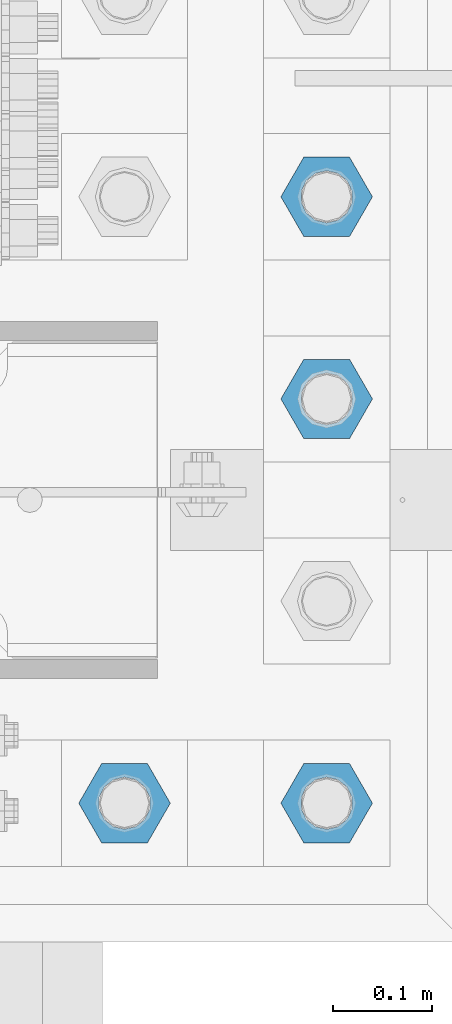
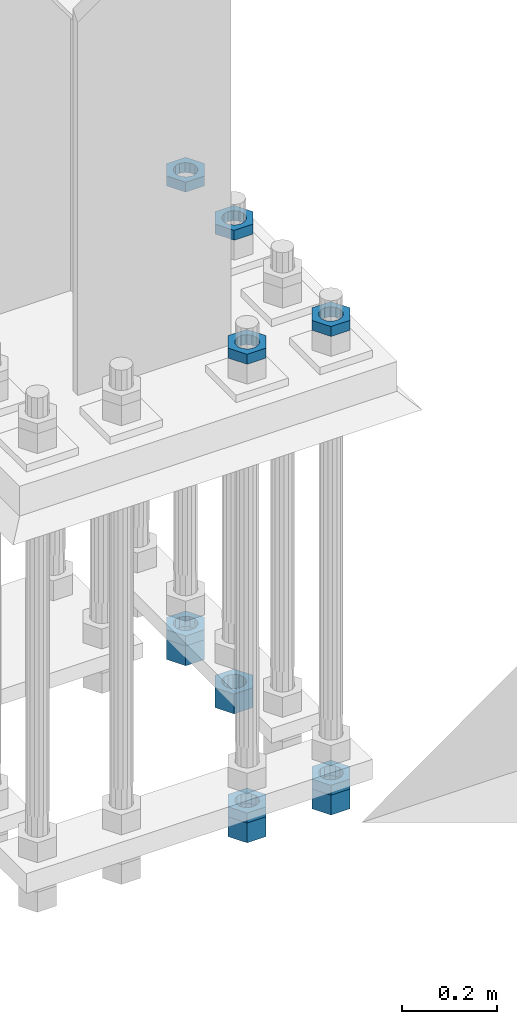
# One storey, part 2093 of 3843: 11 beams, 1 element without a shape of its own.
"""IFC2X3 building model written with IfcOpenShell, lengths in millimetres."""

import ifcopenshell
import ifcopenshell.guid

model = None  # the IFC model being written
_history = None  # IfcOwnerHistory: only IFC2X3 demands one
_inside = {}  # id of a spatial element -> (the spatial element, [elements in it])
_under = {}  # id of a project, library or spatial element -> (it, [spatial elements below it])
_declared = {}  # id of a project -> (the project, [libraries it declares])
_typed = {}  # id of a type object -> (the type object, [elements of that type])
_made_of = {}  # id of a material, layer set ... -> (it, [elements and type objects made of it])


def new_model(schema):
    """Start an empty IFC model of exactly this schema.

    Asked for "IFC4X3", IfcOpenShell would pick the latest addendum, in which some entities
    have other attributes; the version numbers below select the first issue.
    IFC2X3 requires an IfcOwnerHistory on every rooted entity: one is made here for all.
    """
    global model, _history
    if schema == "IFC4X3":
        model = ifcopenshell.file(schema_version=(4, 3, 0, 0))
    else:
        model = ifcopenshell.file(schema=schema)
    _inside.clear()
    _under.clear()
    _declared.clear()
    _typed.clear()
    _made_of.clear()
    _history = None
    if model.schema == "IFC2X3":
        org = make("IfcOrganization", Name="unknown")
        user = make(
            "IfcPersonAndOrganization",
            ThePerson=make("IfcPerson", FamilyName="unknown"),
            TheOrganization=org,
        )
        app = make(
            "IfcApplication",
            ApplicationDeveloper=org,
            Version="unknown",
            ApplicationFullName="unknown",
            ApplicationIdentifier="unknown",
        )
        _history = make(
            "IfcOwnerHistory",
            OwningUser=user,
            OwningApplication=app,
            ChangeAction="ADDED",
            CreationDate=0,
        )
    return model


def make(cls, **values):
    """One entity of the class cls with the attributes given. An attribute that is None is left unset."""
    return model.create_entity(
        cls, **{name: value for name, value in values.items() if value is not None}
    )


def rooted(cls, **values):
    """An entity with a GlobalId (a new one), such as an element, a storey or a relation."""
    return make(cls, GlobalId=ifcopenshell.guid.new(), OwnerHistory=_history, **values)


def si_unit(unit_type, name, prefix=None):
    """IfcSIUnit, for example si_unit("LENGTHUNIT", "METRE", prefix="MILLI")."""
    return make("IfcSIUnit", UnitType=unit_type, Prefix=prefix, Name=name)


def assignment(units):
    """IfcUnitAssignment: the units of a project."""
    return None if units is None else make("IfcUnitAssignment", Units=units)


def point(xyz):
    """IfcCartesianPoint."""
    return None if xyz is None else make("IfcCartesianPoint", Coordinates=xyz)


def direction(xyz):
    """IfcDirection."""
    return None if xyz is None else make("IfcDirection", DirectionRatios=xyz)


def frame(location, z_axis=None, x_axis=None):
    """IfcAxis2Placement3D, a coordinate frame: its origin and axes. An axis left out is left unset."""
    return make(
        "IfcAxis2Placement3D",
        Location=point(location),
        Axis=direction(z_axis),
        RefDirection=direction(x_axis),
    )


def origin_with_axes():
    """The frame at (0, 0, 0) with the z axis (0, 0, 1) and the x axis (1, 0, 0) written out."""
    return frame((0.0, 0.0, 0.0), z_axis=(0.0, 0.0, 1.0), x_axis=(1.0, 0.0, 0.0))


def place(relative_to, where):
    """IfcLocalPlacement: puts the frame where relative to a parent placement (None: the world)."""
    return make(
        "IfcLocalPlacement", PlacementRelTo=relative_to, RelativePlacement=where
    )


def context(
    kind, dimensions, precision=None, world=None, true_north=None, identifier=None
):
    """IfcGeometricRepresentationContext, for example the 3D "Model" context."""
    return make(
        "IfcGeometricRepresentationContext",
        ContextIdentifier=identifier,
        ContextType=kind,
        CoordinateSpaceDimension=dimensions,
        Precision=precision,
        WorldCoordinateSystem=world,
        TrueNorth=true_north,
    )


def subcontext(parent, identifier, kind, view, scale=None):
    """IfcGeometricRepresentationSubContext, for example "Body" below "Model"."""
    return make(
        "IfcGeometricRepresentationSubContext",
        ContextIdentifier=identifier,
        ContextType=kind,
        ParentContext=parent,
        TargetScale=scale,
        TargetView=view,
    )


def project(units=None, contexts=None):
    """IfcProject with its units and contexts."""
    return rooted(
        "IfcProject",
        Name="project",
        RepresentationContexts=contexts,
        UnitsInContext=assignment(units),
    )


def spatial(cls, under=None, at=None, **own):
    """A site, building, storey or space (cls), placed at a placement, below another one or the project."""
    s = rooted(cls, ObjectPlacement=at, **own)
    if under is not None:
        _under.setdefault(under.id(), (under, []))[1].append(s)
    return s


def faces_of(points, faces, orient=None, outer=None):
    """IfcFace entities. A face is a list of loops; a loop is a list of indices into points, from 0.

    orient and outer hold one flag for each loop. By default every Orientation is true, the
    first loop of a face is its IfcFaceOuterBound and the others are IfcFaceBound.
    """
    made = []
    for i, loops in enumerate(faces):
        bounds = []
        for j, loop in enumerate(loops):
            is_outer = j == 0 if outer is None else outer[i][j]
            bounds.append(
                make(
                    "IfcFaceOuterBound" if is_outer else "IfcFaceBound",
                    Bound=make("IfcPolyLoop", Polygon=[points[k] for k in loop]),
                    Orientation=True if orient is None else orient[i][j],
                )
            )
        made.append(make("IfcFace", Bounds=bounds))
    return made


def faceted_brep(points, faces, orient=None, outer=None, voids=None):
    """IfcFacetedBrep: a solid bounded by flat faces; with voids (closed shells), ...WithVoids."""
    shared = [point(p) for p in points]
    hull = make("IfcClosedShell", CfsFaces=faces_of(shared, faces, orient, outer))
    if voids is None:
        return make("IfcFacetedBrep", Outer=hull)
    return make(
        "IfcFacetedBrepWithVoids",
        Outer=hull,
        Voids=[
            make(cls, CfsFaces=faces_of(shared, fs, o, b)) for cls, fs, o, b in voids
        ],
    )


def shape(context_of_items, identifier, shape_type, items):
    """IfcShapeRepresentation: the items that make up one representation, for example the "Body"."""
    return make(
        "IfcShapeRepresentation",
        ContextOfItems=context_of_items,
        RepresentationIdentifier=identifier,
        RepresentationType=shape_type,
        Items=items,
    )


def material(Name=None, Category=None):
    """IfcMaterial."""
    return make("IfcMaterial", Name=Name, Category=Category)


def made_of(thing, what):
    """Note that an element or type object is made of a material, layer set ...; save() writes the relation."""
    if what is not None:
        _made_of.setdefault(what.id(), (what, []))[1].append(thing)
    return thing


def type_object(cls, material=None, **own):
    """A type object (cls), such as IfcWallType, which elements share."""
    return made_of(rooted(cls, **own), material)


def element(
    cls,
    number,
    at=None,
    inside=None,
    cuts=None,
    type_object=None,
    material=None,
    context=None,
    identifier="Body",
    shape_type=None,
    held_by="IfcProductDefinitionShape",
    body=None,
    shapes=None,
    **own,
):
    """One element of the class cls, such as IfcWall. Its Tag is "e" and its number.

    at: its placement. inside: the storey or other place that contains it. cuts: it is an
    opening in that element (IfcRelVoidsElement). A single representation is given by context,
    identifier, shape_type and body (its items); several are given by shapes. held_by: the class
    of the entity that holds the representations. save() writes the other relations.
    """
    e = rooted(cls, Tag="e%d" % number, ObjectPlacement=at, **own)
    if body is not None:
        shapes = [shape(context, identifier, shape_type, body)]
    if shapes is not None:
        e.Representation = make(held_by, Representations=shapes)
    if inside is not None:
        _inside.setdefault(inside.id(), (inside, []))[1].append(e)
    if cuts is not None:
        rooted(
            "IfcRelVoidsElement", RelatingBuildingElement=cuts, RelatedOpeningElement=e
        )
    if type_object is not None:
        _typed.setdefault(type_object.id(), (type_object, []))[1].append(e)
    return made_of(e, material)


def aggregate(whole, parts):
    """IfcRelAggregates: a whole, such as a stair, and the parts it consists of."""
    return rooted("IfcRelAggregates", RelatingObject=whole, RelatedObjects=parts)


def save(model, path):
    """Write the relations noted so far, then the file.

    IfcRelAggregates (storeys below a building ...), IfcRelContainedInSpatialStructure (elements
    in a storey), IfcRelDefinesByType, IfcRelAssociatesMaterial and IfcRelDeclares: one each for
    every whole, place, type object, material and project.
    """
    for whole, parts in _under.values():
        aggregate(whole, parts)
    for where, things in _inside.values():
        rooted(
            "IfcRelContainedInSpatialStructure",
            RelatedElements=things,
            RelatingStructure=where,
        )
    for kind, things in _typed.values():
        rooted("IfcRelDefinesByType", RelatedObjects=things, RelatingType=kind)
    for what, things in _made_of.values():
        rooted("IfcRelAssociatesMaterial", RelatedObjects=things, RelatingMaterial=what)
    for by, libraries in _declared.values():
        rooted("IfcRelDeclares", RelatingContext=by, RelatedDefinitions=libraries)
    model.write(path)


model = new_model("IFC2X3")

# Units and contexts
model_context = context("Model", 3, precision=1e-05, world=origin_with_axes())
body_context = subcontext(model_context, "Body", "Model", "MODEL_VIEW")
ifc_project = project(units=[si_unit("LENGTHUNIT", "METRE", prefix="MILLI"), si_unit("AREAUNIT", "SQUARE_METRE"), si_unit("VOLUMEUNIT", "CUBIC_METRE"), si_unit("MASSUNIT", "GRAM", prefix="KILO"), si_unit("TIMEUNIT", "SECOND"), si_unit("PLANEANGLEUNIT", "RADIAN"), si_unit("SOLIDANGLEUNIT", "STERADIAN"), si_unit("THERMODYNAMICTEMPERATUREUNIT", "DEGREE_CELSIUS"), si_unit("LUMINOUSINTENSITYUNIT", "LUMEN")], contexts=[model_context])

# Site, building, storey
site_placement = place(None, origin_with_axes())
site = spatial("IfcSite", under=ifc_project, at=site_placement, CompositionType="ELEMENT")
building_placement = place(site_placement, origin_with_axes())
building = spatial("IfcBuilding", under=site, at=building_placement, Name="Undefined", CompositionType="ELEMENT")
storey_placement = place(building_placement, origin_with_axes())
storey = spatial("IfcBuildingStorey", under=building, at=storey_placement, Name="Undefined", CompositionType="ELEMENT", Elevation=0.0)

# Assembly, beams
assembly_placement = place(storey_placement, origin_with_axes())
assembly = element("IfcElementAssembly", 1, at=assembly_placement, inside=storey, Name="TEMPLATE", AssemblyPlace="NOTDEFINED", PredefinedType="RIGID_FRAME")
ifc_material = material(Name="STEEL/A572-50")
beam_type_1 = type_object("IfcBeamType", Name="2_HALF_NUT", PredefinedType="NOTDEFINED")
beam_1_placement = place(assembly_placement, frame((56083.2, 20002.5, 29775.15), z_axis=(0.0, 1.0, 0.0), x_axis=(0.0, 0.0, -1.0)))
beam_1 = element("IfcBeam", 2, at=beam_1_placement, type_object=beam_type_1, material=ifc_material, Name="NUT", ObjectType="2_HALF_NUT", context=body_context, shape_type="Brep", body=[
    faceted_brep([(0.0, -46.0369987487793, 0.0), (0.0, -23.0184993743896, -39.869213104248), (25.4000000000015, -23.0184993743896, -39.869213104248), (25.4000000000015, -46.0369987487793, 0.0), (0.0, 23.0184993743896, -39.869213104248), (25.4000000000015, 23.0184993743896, -39.869213104248), (0.0, 46.0369987487793, 0.0), (25.4000000000015, 46.0369987487793, 0.0), (0.0, 23.0184993743896, 39.869213104248), (25.4000000000015, 23.0184993743896, 39.869213104248), (0.0, -23.0184993743896, 39.869213104248), (25.4000000000015, -23.0184993743896, 39.869213104248), (0.0, 0.0, 26.1940002441406), (0.0, 11.3650617044477, 23.5999013092805), (25.4000000000015, 11.3650617044477, 23.5999013092805), (25.4000000000015, 0.0, 26.1940002441406), (0.0, 20.4791109456419, 16.3316083006721), (25.4000000000015, 20.4791109456419, 16.3316083006721), (0.0, 25.5370200498292, 5.82867859874386), (25.4000000000015, 25.5370200498292, 5.82867859874386), (0.0, 25.5370200498292, -5.82867859874386), (25.4000000000015, 25.5370200498292, -5.82867859874386), (0.0, 20.4791109456419, -16.3316083006721), (25.4000000000015, 20.4791109456419, -16.3316083006721), (0.0, 11.3650617044477, -23.5999013092805), (25.4000000000015, 11.3650617044477, -23.5999013092805), (0.0, 0.0, -26.1940002441406), (25.4000000000015, 0.0, -26.1940002441406), (0.0, -11.3650617044477, -23.5999013092805), (25.4000000000015, -11.3650617044477, -23.5999013092805), (0.0, -20.4791109456419, -16.3316083006721), (25.4000000000015, -20.4791109456419, -16.3316083006721), (0.0, -25.5370200498292, -5.82867859874386), (25.4000000000015, -25.5370200498292, -5.82867859874386), (0.0, -25.5370200498292, 5.82867859874386), (25.4000000000015, -25.5370200498292, 5.82867859874386), (0.0, -20.4791109456419, 16.3316083006721), (25.4000000000015, -20.4791109456419, 16.3316083006721), (0.0, -11.3650617044477, 23.5999013092805), (25.4000000000015, -11.3650617044477, 23.5999013092805)], [[[0, 1, 2, 3]], [[1, 4, 5, 2]], [[4, 6, 7, 5]], [[6, 8, 9, 7]], [[8, 10, 11, 9]], [[10, 0, 3, 11]], [[12, 13, 14, 15]], [[13, 16, 17, 14]], [[16, 18, 19, 17]], [[18, 20, 21, 19]], [[20, 22, 23, 21]], [[22, 24, 25, 23]], [[24, 26, 27, 25]], [[26, 28, 29, 27]], [[28, 30, 31, 29]], [[30, 32, 33, 31]], [[32, 34, 35, 33]], [[34, 36, 37, 35]], [[36, 38, 39, 37]], [[38, 12, 15, 39]], [[5, 7, 9, 11, 3, 2], [17, 19, 21, 23, 25, 27, 29, 31, 33, 35, 37, 39, 15, 14]], [[10, 8, 6, 4, 1, 0], [38, 36, 34, 32, 30, 28, 26, 24, 22, 20, 18, 16, 13, 12]]]),
])
beam_2_placement = place(assembly_placement, frame((56083.2, 20002.5, 28600.3999969482), z_axis=(0.0, 1.0, 0.0), x_axis=(0.0, 0.0, -1.0)))
beam_2 = element("IfcBeam", 3, at=beam_2_placement, type_object=beam_type_1, material=ifc_material, Name="NUT", ObjectType="2_HALF_NUT", context=body_context, shape_type="Brep", body=[
    faceted_brep([(0.0, -46.0369987487793, 0.0), (0.0, -23.0184993743896, -39.869213104248), (25.4000000000015, -23.0184993743896, -39.869213104248), (25.4000000000015, -46.0369987487793, 0.0), (0.0, 23.0184993743896, -39.869213104248), (25.4000000000015, 23.0184993743896, -39.869213104248), (0.0, 46.0369987487793, 0.0), (25.4000000000015, 46.0369987487793, 0.0), (0.0, 23.0184993743896, 39.869213104248), (25.4000000000015, 23.0184993743896, 39.869213104248), (0.0, -23.0184993743896, 39.869213104248), (25.4000000000015, -23.0184993743896, 39.869213104248), (0.0, 0.0, 26.1940002441406), (0.0, 11.3650617044477, 23.5999013092805), (25.4000000000015, 11.3650617044477, 23.5999013092805), (25.4000000000015, 0.0, 26.1940002441406), (0.0, 20.4791109456419, 16.3316083006721), (25.4000000000015, 20.4791109456419, 16.3316083006721), (0.0, 25.5370200498292, 5.82867859874386), (25.4000000000015, 25.5370200498292, 5.82867859874386), (0.0, 25.5370200498292, -5.82867859874386), (25.4000000000015, 25.5370200498292, -5.82867859874386), (0.0, 20.4791109456419, -16.3316083006721), (25.4000000000015, 20.4791109456419, -16.3316083006721), (0.0, 11.3650617044477, -23.5999013092805), (25.4000000000015, 11.3650617044477, -23.5999013092805), (0.0, 0.0, -26.1940002441406), (25.4000000000015, 0.0, -26.1940002441406), (0.0, -11.3650617044477, -23.5999013092805), (25.4000000000015, -11.3650617044477, -23.5999013092805), (0.0, -20.4791109456419, -16.3316083006721), (25.4000000000015, -20.4791109456419, -16.3316083006721), (0.0, -25.5370200498292, -5.82867859874386), (25.4000000000015, -25.5370200498292, -5.82867859874386), (0.0, -25.5370200498292, 5.82867859874386), (25.4000000000015, -25.5370200498292, 5.82867859874386), (0.0, -20.4791109456419, 16.3316083006721), (25.4000000000015, -20.4791109456419, 16.3316083006721), (0.0, -11.3650617044477, 23.5999013092805), (25.4000000000015, -11.3650617044477, 23.5999013092805)], [[[0, 1, 2, 3]], [[1, 4, 5, 2]], [[4, 6, 7, 5]], [[6, 8, 9, 7]], [[8, 10, 11, 9]], [[10, 0, 3, 11]], [[12, 13, 14, 15]], [[13, 16, 17, 14]], [[16, 18, 19, 17]], [[18, 20, 21, 19]], [[20, 22, 23, 21]], [[22, 24, 25, 23]], [[24, 26, 27, 25]], [[26, 28, 29, 27]], [[28, 30, 31, 29]], [[30, 32, 33, 31]], [[32, 34, 35, 33]], [[34, 36, 37, 35]], [[36, 38, 39, 37]], [[38, 12, 15, 39]], [[5, 7, 9, 11, 3, 2], [17, 19, 21, 23, 25, 27, 29, 31, 33, 35, 37, 39, 15, 14]], [[10, 8, 6, 4, 1, 0], [38, 36, 34, 32, 30, 28, 26, 24, 22, 20, 18, 16, 13, 12]]]),
])
beam_3_placement = place(assembly_placement, frame((56286.4, 20002.5, 29775.15), z_axis=(0.0, 1.0, 0.0), x_axis=(0.0, 0.0, -1.0)))
beam_3 = element("IfcBeam", 4, at=beam_3_placement, type_object=beam_type_1, material=ifc_material, Name="NUT", ObjectType="2_HALF_NUT", context=body_context, shape_type="Brep", body=[
    faceted_brep([(0.0, -46.0369987487793, 0.0), (0.0, -23.0184993743896, -39.869213104248), (25.4000000000015, -23.0184993743896, -39.869213104248), (25.4000000000015, -46.0369987487793, 0.0), (0.0, 23.0184993743896, -39.869213104248), (25.4000000000015, 23.0184993743896, -39.869213104248), (0.0, 46.0369987487793, 0.0), (25.4000000000015, 46.0369987487793, 0.0), (0.0, 23.0184993743896, 39.869213104248), (25.4000000000015, 23.0184993743896, 39.869213104248), (0.0, -23.0184993743896, 39.869213104248), (25.4000000000015, -23.0184993743896, 39.869213104248), (0.0, 0.0, 26.1940002441406), (0.0, 11.3650617044477, 23.5999013092805), (25.4000000000015, 11.3650617044477, 23.5999013092805), (25.4000000000015, 0.0, 26.1940002441406), (0.0, 20.4791109456419, 16.3316083006721), (25.4000000000015, 20.4791109456419, 16.3316083006721), (0.0, 25.5370200498292, 5.82867859874386), (25.4000000000015, 25.5370200498292, 5.82867859874386), (0.0, 25.5370200498292, -5.82867859874386), (25.4000000000015, 25.5370200498292, -5.82867859874386), (0.0, 20.4791109456419, -16.3316083006721), (25.4000000000015, 20.4791109456419, -16.3316083006721), (0.0, 11.3650617044477, -23.5999013092805), (25.4000000000015, 11.3650617044477, -23.5999013092805), (0.0, 0.0, -26.1940002441406), (25.4000000000015, 0.0, -26.1940002441406), (0.0, -11.3650617044477, -23.5999013092805), (25.4000000000015, -11.3650617044477, -23.5999013092805), (0.0, -20.4791109456419, -16.3316083006721), (25.4000000000015, -20.4791109456419, -16.3316083006721), (0.0, -25.5370200498292, -5.82867859874386), (25.4000000000015, -25.5370200498292, -5.82867859874386), (0.0, -25.5370200498292, 5.82867859874386), (25.4000000000015, -25.5370200498292, 5.82867859874386), (0.0, -20.4791109456419, 16.3316083006721), (25.4000000000015, -20.4791109456419, 16.3316083006721), (0.0, -11.3650617044477, 23.5999013092805), (25.4000000000015, -11.3650617044477, 23.5999013092805)], [[[0, 1, 2, 3]], [[1, 4, 5, 2]], [[4, 6, 7, 5]], [[6, 8, 9, 7]], [[8, 10, 11, 9]], [[10, 0, 3, 11]], [[12, 13, 14, 15]], [[13, 16, 17, 14]], [[16, 18, 19, 17]], [[18, 20, 21, 19]], [[20, 22, 23, 21]], [[22, 24, 25, 23]], [[24, 26, 27, 25]], [[26, 28, 29, 27]], [[28, 30, 31, 29]], [[30, 32, 33, 31]], [[32, 34, 35, 33]], [[34, 36, 37, 35]], [[36, 38, 39, 37]], [[38, 12, 15, 39]], [[5, 7, 9, 11, 3, 2], [17, 19, 21, 23, 25, 27, 29, 31, 33, 35, 37, 39, 15, 14]], [[10, 8, 6, 4, 1, 0], [38, 36, 34, 32, 30, 28, 26, 24, 22, 20, 18, 16, 13, 12]]]),
])
beam_4_placement = place(assembly_placement, frame((56286.4, 20002.5, 28600.3999969482), z_axis=(0.0, 1.0, 0.0), x_axis=(0.0, 0.0, -1.0)))
beam_4 = element("IfcBeam", 5, at=beam_4_placement, type_object=beam_type_1, material=ifc_material, Name="NUT", ObjectType="2_HALF_NUT", context=body_context, shape_type="Brep", body=[
    faceted_brep([(0.0, -46.0369987487793, 0.0), (0.0, -23.0184993743896, -39.869213104248), (25.4000000000015, -23.0184993743896, -39.869213104248), (25.4000000000015, -46.0369987487793, 0.0), (0.0, 23.0184993743896, -39.869213104248), (25.4000000000015, 23.0184993743896, -39.869213104248), (0.0, 46.0369987487793, 0.0), (25.4000000000015, 46.0369987487793, 0.0), (0.0, 23.0184993743896, 39.869213104248), (25.4000000000015, 23.0184993743896, 39.869213104248), (0.0, -23.0184993743896, 39.869213104248), (25.4000000000015, -23.0184993743896, 39.869213104248), (0.0, 0.0, 26.1940002441406), (0.0, 11.3650617044477, 23.5999013092805), (25.4000000000015, 11.3650617044477, 23.5999013092805), (25.4000000000015, 0.0, 26.1940002441406), (0.0, 20.4791109456419, 16.3316083006721), (25.4000000000015, 20.4791109456419, 16.3316083006721), (0.0, 25.5370200498292, 5.82867859874386), (25.4000000000015, 25.5370200498292, 5.82867859874386), (0.0, 25.5370200498292, -5.82867859874386), (25.4000000000015, 25.5370200498292, -5.82867859874386), (0.0, 20.4791109456419, -16.3316083006721), (25.4000000000015, 20.4791109456419, -16.3316083006721), (0.0, 11.3650617044477, -23.5999013092805), (25.4000000000015, 11.3650617044477, -23.5999013092805), (0.0, 0.0, -26.1940002441406), (25.4000000000015, 0.0, -26.1940002441406), (0.0, -11.3650617044477, -23.5999013092805), (25.4000000000015, -11.3650617044477, -23.5999013092805), (0.0, -20.4791109456419, -16.3316083006721), (25.4000000000015, -20.4791109456419, -16.3316083006721), (0.0, -25.5370200498292, -5.82867859874386), (25.4000000000015, -25.5370200498292, -5.82867859874386), (0.0, -25.5370200498292, 5.82867859874386), (25.4000000000015, -25.5370200498292, 5.82867859874386), (0.0, -20.4791109456419, 16.3316083006721), (25.4000000000015, -20.4791109456419, 16.3316083006721), (0.0, -11.3650617044477, 23.5999013092805), (25.4000000000015, -11.3650617044477, 23.5999013092805)], [[[0, 1, 2, 3]], [[1, 4, 5, 2]], [[4, 6, 7, 5]], [[6, 8, 9, 7]], [[8, 10, 11, 9]], [[10, 0, 3, 11]], [[12, 13, 14, 15]], [[13, 16, 17, 14]], [[16, 18, 19, 17]], [[18, 20, 21, 19]], [[20, 22, 23, 21]], [[22, 24, 25, 23]], [[24, 26, 27, 25]], [[26, 28, 29, 27]], [[28, 30, 31, 29]], [[30, 32, 33, 31]], [[32, 34, 35, 33]], [[34, 36, 37, 35]], [[36, 38, 39, 37]], [[38, 12, 15, 39]], [[5, 7, 9, 11, 3, 2], [17, 19, 21, 23, 25, 27, 29, 31, 33, 35, 37, 39, 15, 14]], [[10, 8, 6, 4, 1, 0], [38, 36, 34, 32, 30, 28, 26, 24, 22, 20, 18, 16, 13, 12]]]),
])
beam_5_placement = place(assembly_placement, frame((56286.4, 20612.1, 29775.15), z_axis=(0.0, 1.0, 0.0), x_axis=(0.0, 0.0, -1.0)))
beam_5 = element("IfcBeam", 6, at=beam_5_placement, type_object=beam_type_1, material=ifc_material, Name="NUT", ObjectType="2_HALF_NUT", context=body_context, shape_type="Brep", body=[
    faceted_brep([(0.0, -46.0369987487793, 0.0), (0.0, -23.0184993743896, -39.869213104248), (25.4000000000015, -23.0184993743896, -39.869213104248), (25.4000000000015, -46.0369987487793, 0.0), (0.0, 23.0184993743896, -39.869213104248), (25.4000000000015, 23.0184993743896, -39.869213104248), (0.0, 46.0369987487793, 0.0), (25.4000000000015, 46.0369987487793, 0.0), (0.0, 23.0184993743896, 39.869213104248), (25.4000000000015, 23.0184993743896, 39.869213104248), (0.0, -23.0184993743896, 39.869213104248), (25.4000000000015, -23.0184993743896, 39.869213104248), (0.0, 0.0, 26.1940002441406), (0.0, 11.3650617044477, 23.5999013092805), (25.4000000000015, 11.3650617044477, 23.5999013092805), (25.4000000000015, 0.0, 26.1940002441406), (0.0, 20.4791109456419, 16.3316083006721), (25.4000000000015, 20.4791109456419, 16.3316083006721), (0.0, 25.5370200498292, 5.82867859874386), (25.4000000000015, 25.5370200498292, 5.82867859874386), (0.0, 25.5370200498292, -5.82867859874386), (25.4000000000015, 25.5370200498292, -5.82867859874386), (0.0, 20.4791109456419, -16.3316083006721), (25.4000000000015, 20.4791109456419, -16.3316083006721), (0.0, 11.3650617044477, -23.5999013092805), (25.4000000000015, 11.3650617044477, -23.5999013092805), (0.0, 0.0, -26.1940002441406), (25.4000000000015, 0.0, -26.1940002441406), (0.0, -11.3650617044477, -23.5999013092805), (25.4000000000015, -11.3650617044477, -23.5999013092805), (0.0, -20.4791109456419, -16.3316083006721), (25.4000000000015, -20.4791109456419, -16.3316083006721), (0.0, -25.5370200498292, -5.82867859874386), (25.4000000000015, -25.5370200498292, -5.82867859874386), (0.0, -25.5370200498292, 5.82867859874386), (25.4000000000015, -25.5370200498292, 5.82867859874386), (0.0, -20.4791109456419, 16.3316083006721), (25.4000000000015, -20.4791109456419, 16.3316083006721), (0.0, -11.3650617044477, 23.5999013092805), (25.4000000000015, -11.3650617044477, 23.5999013092805)], [[[0, 1, 2, 3]], [[1, 4, 5, 2]], [[4, 6, 7, 5]], [[6, 8, 9, 7]], [[8, 10, 11, 9]], [[10, 0, 3, 11]], [[12, 13, 14, 15]], [[13, 16, 17, 14]], [[16, 18, 19, 17]], [[18, 20, 21, 19]], [[20, 22, 23, 21]], [[22, 24, 25, 23]], [[24, 26, 27, 25]], [[26, 28, 29, 27]], [[28, 30, 31, 29]], [[30, 32, 33, 31]], [[32, 34, 35, 33]], [[34, 36, 37, 35]], [[36, 38, 39, 37]], [[38, 12, 15, 39]], [[5, 7, 9, 11, 3, 2], [17, 19, 21, 23, 25, 27, 29, 31, 33, 35, 37, 39, 15, 14]], [[10, 8, 6, 4, 1, 0], [38, 36, 34, 32, 30, 28, 26, 24, 22, 20, 18, 16, 13, 12]]]),
])
beam_6_placement = place(assembly_placement, frame((56286.4, 20612.1, 28613.0999969482), z_axis=(0.0, 1.0, 0.0), x_axis=(0.0, 0.0, -1.0)))
beam_6 = element("IfcBeam", 7, at=beam_6_placement, type_object=beam_type_1, material=ifc_material, Name="NUT", ObjectType="2_HALF_NUT", context=body_context, shape_type="Brep", body=[
    faceted_brep([(0.0, -46.0369987487793, 0.0), (0.0, -23.0184993743896, -39.869213104248), (25.4000000000015, -23.0184993743896, -39.869213104248), (25.4000000000015, -46.0369987487793, 0.0), (0.0, 23.0184993743896, -39.869213104248), (25.4000000000015, 23.0184993743896, -39.869213104248), (0.0, 46.0369987487793, 0.0), (25.4000000000015, 46.0369987487793, 0.0), (0.0, 23.0184993743896, 39.869213104248), (25.4000000000015, 23.0184993743896, 39.869213104248), (0.0, -23.0184993743896, 39.869213104248), (25.4000000000015, -23.0184993743896, 39.869213104248), (0.0, 0.0, 26.1940002441406), (0.0, 11.3650617044477, 23.5999013092805), (25.4000000000015, 11.3650617044477, 23.5999013092805), (25.4000000000015, 0.0, 26.1940002441406), (0.0, 20.4791109456419, 16.3316083006721), (25.4000000000015, 20.4791109456419, 16.3316083006721), (0.0, 25.5370200498292, 5.82867859874386), (25.4000000000015, 25.5370200498292, 5.82867859874386), (0.0, 25.5370200498292, -5.82867859874386), (25.4000000000015, 25.5370200498292, -5.82867859874386), (0.0, 20.4791109456419, -16.3316083006721), (25.4000000000015, 20.4791109456419, -16.3316083006721), (0.0, 11.3650617044477, -23.5999013092805), (25.4000000000015, 11.3650617044477, -23.5999013092805), (0.0, 0.0, -26.1940002441406), (25.4000000000015, 0.0, -26.1940002441406), (0.0, -11.3650617044477, -23.5999013092805), (25.4000000000015, -11.3650617044477, -23.5999013092805), (0.0, -20.4791109456419, -16.3316083006721), (25.4000000000015, -20.4791109456419, -16.3316083006721), (0.0, -25.5370200498292, -5.82867859874386), (25.4000000000015, -25.5370200498292, -5.82867859874386), (0.0, -25.5370200498292, 5.82867859874386), (25.4000000000015, -25.5370200498292, 5.82867859874386), (0.0, -20.4791109456419, 16.3316083006721), (25.4000000000015, -20.4791109456419, 16.3316083006721), (0.0, -11.3650617044477, 23.5999013092805), (25.4000000000015, -11.3650617044477, 23.5999013092805)], [[[0, 1, 2, 3]], [[1, 4, 5, 2]], [[4, 6, 7, 5]], [[6, 8, 9, 7]], [[8, 10, 11, 9]], [[10, 0, 3, 11]], [[12, 13, 14, 15]], [[13, 16, 17, 14]], [[16, 18, 19, 17]], [[18, 20, 21, 19]], [[20, 22, 23, 21]], [[22, 24, 25, 23]], [[24, 26, 27, 25]], [[26, 28, 29, 27]], [[28, 30, 31, 29]], [[30, 32, 33, 31]], [[32, 34, 35, 33]], [[34, 36, 37, 35]], [[36, 38, 39, 37]], [[38, 12, 15, 39]], [[5, 7, 9, 11, 3, 2], [17, 19, 21, 23, 25, 27, 29, 31, 33, 35, 37, 39, 15, 14]], [[10, 8, 6, 4, 1, 0], [38, 36, 34, 32, 30, 28, 26, 24, 22, 20, 18, 16, 13, 12]]]),
])
beam_7_placement = place(assembly_placement, frame((56286.4, 20408.9, 29775.15), z_axis=(0.0, 1.0, 0.0), x_axis=(0.0, 0.0, -1.0)))
beam_7 = element("IfcBeam", 8, at=beam_7_placement, type_object=beam_type_1, material=ifc_material, Name="NUT", ObjectType="2_HALF_NUT", context=body_context, shape_type="Brep", body=[
    faceted_brep([(0.0, -46.0369987487793, 0.0), (0.0, -23.0184993743896, -39.869213104248), (25.4000000000015, -23.0184993743896, -39.869213104248), (25.4000000000015, -46.0369987487793, 0.0), (0.0, 23.0184993743896, -39.869213104248), (25.4000000000015, 23.0184993743896, -39.869213104248), (0.0, 46.0369987487793, 0.0), (25.4000000000015, 46.0369987487793, 0.0), (0.0, 23.0184993743896, 39.869213104248), (25.4000000000015, 23.0184993743896, 39.869213104248), (0.0, -23.0184993743896, 39.869213104248), (25.4000000000015, -23.0184993743896, 39.869213104248), (0.0, 0.0, 26.1940002441406), (0.0, 11.3650617044477, 23.5999013092805), (25.4000000000015, 11.3650617044477, 23.5999013092805), (25.4000000000015, 0.0, 26.1940002441406), (0.0, 20.4791109456419, 16.3316083006721), (25.4000000000015, 20.4791109456419, 16.3316083006721), (0.0, 25.5370200498292, 5.82867859874386), (25.4000000000015, 25.5370200498292, 5.82867859874386), (0.0, 25.5370200498292, -5.82867859874386), (25.4000000000015, 25.5370200498292, -5.82867859874386), (0.0, 20.4791109456419, -16.3316083006721), (25.4000000000015, 20.4791109456419, -16.3316083006721), (0.0, 11.3650617044477, -23.5999013092805), (25.4000000000015, 11.3650617044477, -23.5999013092805), (0.0, 0.0, -26.1940002441406), (25.4000000000015, 0.0, -26.1940002441406), (0.0, -11.3650617044477, -23.5999013092805), (25.4000000000015, -11.3650617044477, -23.5999013092805), (0.0, -20.4791109456419, -16.3316083006721), (25.4000000000015, -20.4791109456419, -16.3316083006721), (0.0, -25.5370200498292, -5.82867859874386), (25.4000000000015, -25.5370200498292, -5.82867859874386), (0.0, -25.5370200498292, 5.82867859874386), (25.4000000000015, -25.5370200498292, 5.82867859874386), (0.0, -20.4791109456419, 16.3316083006721), (25.4000000000015, -20.4791109456419, 16.3316083006721), (0.0, -11.3650617044477, 23.5999013092805), (25.4000000000015, -11.3650617044477, 23.5999013092805)], [[[0, 1, 2, 3]], [[1, 4, 5, 2]], [[4, 6, 7, 5]], [[6, 8, 9, 7]], [[8, 10, 11, 9]], [[10, 0, 3, 11]], [[12, 13, 14, 15]], [[13, 16, 17, 14]], [[16, 18, 19, 17]], [[18, 20, 21, 19]], [[20, 22, 23, 21]], [[22, 24, 25, 23]], [[24, 26, 27, 25]], [[26, 28, 29, 27]], [[28, 30, 31, 29]], [[30, 32, 33, 31]], [[32, 34, 35, 33]], [[34, 36, 37, 35]], [[36, 38, 39, 37]], [[38, 12, 15, 39]], [[5, 7, 9, 11, 3, 2], [17, 19, 21, 23, 25, 27, 29, 31, 33, 35, 37, 39, 15, 14]], [[10, 8, 6, 4, 1, 0], [38, 36, 34, 32, 30, 28, 26, 24, 22, 20, 18, 16, 13, 12]]]),
])
beam_type_2 = type_object("IfcBeamType", Name="2_HEAVY_HEX_NUT", PredefinedType="NOTDEFINED")
beam_8_placement = place(assembly_placement, frame((56083.2, 20002.5, 28574.9999969482), z_axis=(0.0, 1.0, 0.0), x_axis=(0.0, 0.0, -1.0)))
beam_8 = element("IfcBeam", 9, at=beam_8_placement, type_object=beam_type_2, material=ifc_material, Name="NUT", ObjectType="2_HEAVY_HEX_NUT", context=body_context, shape_type="Brep", body=[
    faceted_brep([(0.0, -46.0369987487793, 0.0), (0.0, -23.0184993743896, -39.869213104248), (50.7999999999993, -23.0184993743896, -39.869213104248), (50.7999999999993, -46.0369987487793, 0.0), (0.0, 23.0184993743896, -39.869213104248), (50.7999999999993, 23.0184993743896, -39.869213104248), (0.0, 46.0369987487793, 0.0), (50.7999999999993, 46.0369987487793, 0.0), (0.0, 23.0184993743896, 39.869213104248), (50.7999999999993, 23.0184993743896, 39.869213104248), (0.0, -23.0184993743896, 39.869213104248), (50.7999999999993, -23.0184993743896, 39.869213104248), (0.0, 0.0, 26.1940002441406), (0.0, 11.3650617044477, 23.5999013092805), (50.7999999999993, 11.3650617044477, 23.5999013092805), (50.7999999999993, 0.0, 26.1940002441406), (0.0, 20.4791109456419, 16.3316083006721), (50.7999999999993, 20.4791109456419, 16.3316083006721), (0.0, 25.5370200498292, 5.82867859874386), (50.7999999999993, 25.5370200498292, 5.82867859874386), (0.0, 25.5370200498292, -5.82867859874386), (50.7999999999993, 25.5370200498292, -5.82867859874386), (0.0, 20.4791109456419, -16.3316083006721), (50.7999999999993, 20.4791109456419, -16.3316083006721), (0.0, 11.3650617044477, -23.5999013092805), (50.7999999999993, 11.3650617044477, -23.5999013092805), (0.0, 0.0, -26.1940002441406), (50.7999999999993, 0.0, -26.1940002441406), (0.0, -11.3650617044477, -23.5999013092805), (50.7999999999993, -11.3650617044477, -23.5999013092805), (0.0, -20.4791109456419, -16.3316083006721), (50.7999999999993, -20.4791109456419, -16.3316083006721), (0.0, -25.5370200498292, -5.82867859874386), (50.7999999999993, -25.5370200498292, -5.82867859874386), (0.0, -25.5370200498292, 5.82867859874386), (50.7999999999993, -25.5370200498292, 5.82867859874386), (0.0, -20.4791109456419, 16.3316083006721), (50.7999999999993, -20.4791109456419, 16.3316083006721), (0.0, -11.3650617044477, 23.5999013092805), (50.7999999999993, -11.3650617044477, 23.5999013092805)], [[[0, 1, 2, 3]], [[1, 4, 5, 2]], [[4, 6, 7, 5]], [[6, 8, 9, 7]], [[8, 10, 11, 9]], [[10, 0, 3, 11]], [[12, 13, 14, 15]], [[13, 16, 17, 14]], [[16, 18, 19, 17]], [[18, 20, 21, 19]], [[20, 22, 23, 21]], [[22, 24, 25, 23]], [[24, 26, 27, 25]], [[26, 28, 29, 27]], [[28, 30, 31, 29]], [[30, 32, 33, 31]], [[32, 34, 35, 33]], [[34, 36, 37, 35]], [[36, 38, 39, 37]], [[38, 12, 15, 39]], [[5, 7, 9, 11, 3, 2], [17, 19, 21, 23, 25, 27, 29, 31, 33, 35, 37, 39, 15, 14]], [[10, 8, 6, 4, 1, 0], [38, 36, 34, 32, 30, 28, 26, 24, 22, 20, 18, 16, 13, 12]]]),
])
beam_9_placement = place(assembly_placement, frame((56286.4, 20002.5, 28574.9999969482), z_axis=(0.0, 1.0, 0.0), x_axis=(0.0, 0.0, -1.0)))
beam_9 = element("IfcBeam", 10, at=beam_9_placement, type_object=beam_type_2, material=ifc_material, Name="NUT", ObjectType="2_HEAVY_HEX_NUT", context=body_context, shape_type="Brep", body=[
    faceted_brep([(0.0, -46.0369987487793, 0.0), (0.0, -23.0184993743896, -39.869213104248), (50.7999999999993, -23.0184993743896, -39.869213104248), (50.7999999999993, -46.0369987487793, 0.0), (0.0, 23.0184993743896, -39.869213104248), (50.7999999999993, 23.0184993743896, -39.869213104248), (0.0, 46.0369987487793, 0.0), (50.7999999999993, 46.0369987487793, 0.0), (0.0, 23.0184993743896, 39.869213104248), (50.7999999999993, 23.0184993743896, 39.869213104248), (0.0, -23.0184993743896, 39.869213104248), (50.7999999999993, -23.0184993743896, 39.869213104248), (0.0, 0.0, 26.1940002441406), (0.0, 11.3650617044477, 23.5999013092805), (50.7999999999993, 11.3650617044477, 23.5999013092805), (50.7999999999993, 0.0, 26.1940002441406), (0.0, 20.4791109456419, 16.3316083006721), (50.7999999999993, 20.4791109456419, 16.3316083006721), (0.0, 25.5370200498292, 5.82867859874386), (50.7999999999993, 25.5370200498292, 5.82867859874386), (0.0, 25.5370200498292, -5.82867859874386), (50.7999999999993, 25.5370200498292, -5.82867859874386), (0.0, 20.4791109456419, -16.3316083006721), (50.7999999999993, 20.4791109456419, -16.3316083006721), (0.0, 11.3650617044477, -23.5999013092805), (50.7999999999993, 11.3650617044477, -23.5999013092805), (0.0, 0.0, -26.1940002441406), (50.7999999999993, 0.0, -26.1940002441406), (0.0, -11.3650617044477, -23.5999013092805), (50.7999999999993, -11.3650617044477, -23.5999013092805), (0.0, -20.4791109456419, -16.3316083006721), (50.7999999999993, -20.4791109456419, -16.3316083006721), (0.0, -25.5370200498292, -5.82867859874386), (50.7999999999993, -25.5370200498292, -5.82867859874386), (0.0, -25.5370200498292, 5.82867859874386), (50.7999999999993, -25.5370200498292, 5.82867859874386), (0.0, -20.4791109456419, 16.3316083006721), (50.7999999999993, -20.4791109456419, 16.3316083006721), (0.0, -11.3650617044477, 23.5999013092805), (50.7999999999993, -11.3650617044477, 23.5999013092805)], [[[0, 1, 2, 3]], [[1, 4, 5, 2]], [[4, 6, 7, 5]], [[6, 8, 9, 7]], [[8, 10, 11, 9]], [[10, 0, 3, 11]], [[12, 13, 14, 15]], [[13, 16, 17, 14]], [[16, 18, 19, 17]], [[18, 20, 21, 19]], [[20, 22, 23, 21]], [[22, 24, 25, 23]], [[24, 26, 27, 25]], [[26, 28, 29, 27]], [[28, 30, 31, 29]], [[30, 32, 33, 31]], [[32, 34, 35, 33]], [[34, 36, 37, 35]], [[36, 38, 39, 37]], [[38, 12, 15, 39]], [[5, 7, 9, 11, 3, 2], [17, 19, 21, 23, 25, 27, 29, 31, 33, 35, 37, 39, 15, 14]], [[10, 8, 6, 4, 1, 0], [38, 36, 34, 32, 30, 28, 26, 24, 22, 20, 18, 16, 13, 12]]]),
])
beam_10_placement = place(assembly_placement, frame((56286.4, 20612.1, 28587.6999969482), z_axis=(0.0, 1.0, 0.0), x_axis=(0.0, 0.0, -1.0)))
beam_10 = element("IfcBeam", 11, at=beam_10_placement, type_object=beam_type_2, material=ifc_material, Name="NUT", ObjectType="2_HEAVY_HEX_NUT", context=body_context, shape_type="Brep", body=[
    faceted_brep([(0.0, -46.0369987487793, 0.0), (0.0, -23.0184993743896, -39.869213104248), (50.7999999999993, -23.0184993743896, -39.869213104248), (50.7999999999993, -46.0369987487793, 0.0), (0.0, 23.0184993743896, -39.869213104248), (50.7999999999993, 23.0184993743896, -39.869213104248), (0.0, 46.0369987487793, 0.0), (50.7999999999993, 46.0369987487793, 0.0), (0.0, 23.0184993743896, 39.869213104248), (50.7999999999993, 23.0184993743896, 39.869213104248), (0.0, -23.0184993743896, 39.869213104248), (50.7999999999993, -23.0184993743896, 39.869213104248), (0.0, 0.0, 26.1940002441406), (0.0, 11.3650617044477, 23.5999013092805), (50.7999999999993, 11.3650617044477, 23.5999013092805), (50.7999999999993, 0.0, 26.1940002441406), (0.0, 20.4791109456419, 16.3316083006721), (50.7999999999993, 20.4791109456419, 16.3316083006721), (0.0, 25.5370200498292, 5.82867859874386), (50.7999999999993, 25.5370200498292, 5.82867859874386), (0.0, 25.5370200498292, -5.82867859874386), (50.7999999999993, 25.5370200498292, -5.82867859874386), (0.0, 20.4791109456419, -16.3316083006721), (50.7999999999993, 20.4791109456419, -16.3316083006721), (0.0, 11.3650617044477, -23.5999013092805), (50.7999999999993, 11.3650617044477, -23.5999013092805), (0.0, 0.0, -26.1940002441406), (50.7999999999993, 0.0, -26.1940002441406), (0.0, -11.3650617044477, -23.5999013092805), (50.7999999999993, -11.3650617044477, -23.5999013092805), (0.0, -20.4791109456419, -16.3316083006721), (50.7999999999993, -20.4791109456419, -16.3316083006721), (0.0, -25.5370200498292, -5.82867859874386), (50.7999999999993, -25.5370200498292, -5.82867859874386), (0.0, -25.5370200498292, 5.82867859874386), (50.7999999999993, -25.5370200498292, 5.82867859874386), (0.0, -20.4791109456419, 16.3316083006721), (50.7999999999993, -20.4791109456419, 16.3316083006721), (0.0, -11.3650617044477, 23.5999013092805), (50.7999999999993, -11.3650617044477, 23.5999013092805)], [[[0, 1, 2, 3]], [[1, 4, 5, 2]], [[4, 6, 7, 5]], [[6, 8, 9, 7]], [[8, 10, 11, 9]], [[10, 0, 3, 11]], [[12, 13, 14, 15]], [[13, 16, 17, 14]], [[16, 18, 19, 17]], [[18, 20, 21, 19]], [[20, 22, 23, 21]], [[22, 24, 25, 23]], [[24, 26, 27, 25]], [[26, 28, 29, 27]], [[28, 30, 31, 29]], [[30, 32, 33, 31]], [[32, 34, 35, 33]], [[34, 36, 37, 35]], [[36, 38, 39, 37]], [[38, 12, 15, 39]], [[5, 7, 9, 11, 3, 2], [17, 19, 21, 23, 25, 27, 29, 31, 33, 35, 37, 39, 15, 14]], [[10, 8, 6, 4, 1, 0], [38, 36, 34, 32, 30, 28, 26, 24, 22, 20, 18, 16, 13, 12]]]),
])
beam_11_placement = place(assembly_placement, frame((56286.4, 20408.9, 28587.6999969482), z_axis=(0.0, 1.0, 0.0), x_axis=(0.0, 0.0, -1.0)))
beam_11 = element("IfcBeam", 12, at=beam_11_placement, type_object=beam_type_2, material=ifc_material, Name="NUT", ObjectType="2_HEAVY_HEX_NUT", context=body_context, shape_type="Brep", body=[
    faceted_brep([(0.0, -46.0369987487793, 0.0), (0.0, -23.0184993743896, -39.869213104248), (50.7999999999993, -23.0184993743896, -39.869213104248), (50.7999999999993, -46.0369987487793, 0.0), (0.0, 23.0184993743896, -39.869213104248), (50.7999999999993, 23.0184993743896, -39.869213104248), (0.0, 46.0369987487793, 0.0), (50.7999999999993, 46.0369987487793, 0.0), (0.0, 23.0184993743896, 39.869213104248), (50.7999999999993, 23.0184993743896, 39.869213104248), (0.0, -23.0184993743896, 39.869213104248), (50.7999999999993, -23.0184993743896, 39.869213104248), (0.0, 0.0, 26.1940002441406), (0.0, 11.3650617044477, 23.5999013092805), (50.7999999999993, 11.3650617044477, 23.5999013092805), (50.7999999999993, 0.0, 26.1940002441406), (0.0, 20.4791109456419, 16.3316083006721), (50.7999999999993, 20.4791109456419, 16.3316083006721), (0.0, 25.5370200498292, 5.82867859874386), (50.7999999999993, 25.5370200498292, 5.82867859874386), (0.0, 25.5370200498292, -5.82867859874386), (50.7999999999993, 25.5370200498292, -5.82867859874386), (0.0, 20.4791109456419, -16.3316083006721), (50.7999999999993, 20.4791109456419, -16.3316083006721), (0.0, 11.3650617044477, -23.5999013092805), (50.7999999999993, 11.3650617044477, -23.5999013092805), (0.0, 0.0, -26.1940002441406), (50.7999999999993, 0.0, -26.1940002441406), (0.0, -11.3650617044477, -23.5999013092805), (50.7999999999993, -11.3650617044477, -23.5999013092805), (0.0, -20.4791109456419, -16.3316083006721), (50.7999999999993, -20.4791109456419, -16.3316083006721), (0.0, -25.5370200498292, -5.82867859874386), (50.7999999999993, -25.5370200498292, -5.82867859874386), (0.0, -25.5370200498292, 5.82867859874386), (50.7999999999993, -25.5370200498292, 5.82867859874386), (0.0, -20.4791109456419, 16.3316083006721), (50.7999999999993, -20.4791109456419, 16.3316083006721), (0.0, -11.3650617044477, 23.5999013092805), (50.7999999999993, -11.3650617044477, 23.5999013092805)], [[[0, 1, 2, 3]], [[1, 4, 5, 2]], [[4, 6, 7, 5]], [[6, 8, 9, 7]], [[8, 10, 11, 9]], [[10, 0, 3, 11]], [[12, 13, 14, 15]], [[13, 16, 17, 14]], [[16, 18, 19, 17]], [[18, 20, 21, 19]], [[20, 22, 23, 21]], [[22, 24, 25, 23]], [[24, 26, 27, 25]], [[26, 28, 29, 27]], [[28, 30, 31, 29]], [[30, 32, 33, 31]], [[32, 34, 35, 33]], [[34, 36, 37, 35]], [[36, 38, 39, 37]], [[38, 12, 15, 39]], [[5, 7, 9, 11, 3, 2], [17, 19, 21, 23, 25, 27, 29, 31, 33, 35, 37, 39, 15, 14]], [[10, 8, 6, 4, 1, 0], [38, 36, 34, 32, 30, 28, 26, 24, 22, 20, 18, 16, 13, 12]]]),
])
aggregate(assembly, [beam_1, beam_8, beam_2, beam_3, beam_9, beam_4, beam_5, beam_10, beam_6, beam_7, beam_11])

save(model, "model.ifc")
